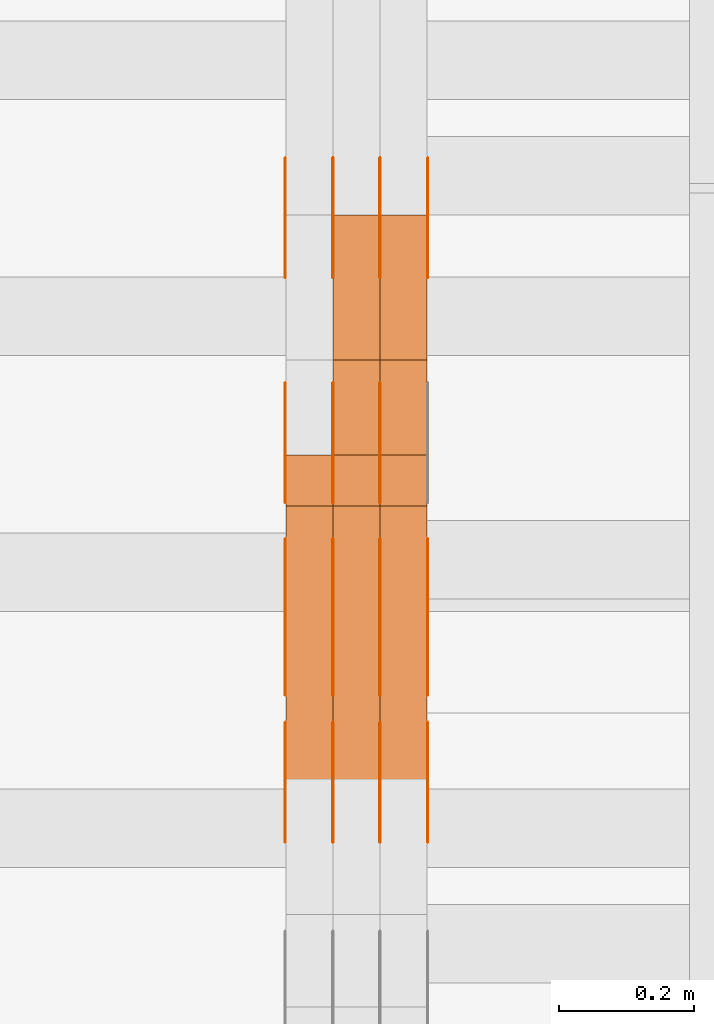
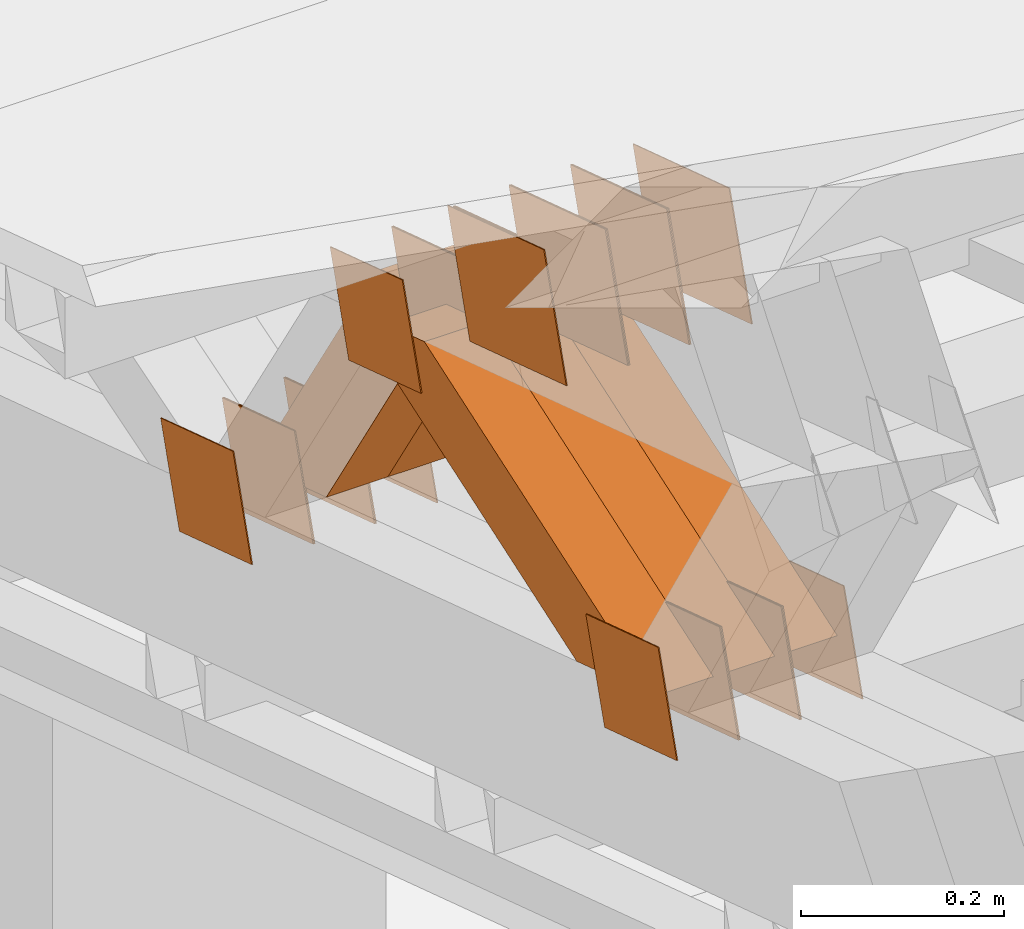
# One storey, part 171 of 385: 28 proxies.
"""IFC2X3 building model written with IfcOpenShell, lengths in millimetres."""

from ifc_helpers import new_model, entity, si_unit, converted_unit, derived_unit, direction, frame, origin, place, context, subcontext, project, spatial, polyline, outline, extrude, source, transform, mapped, material, type_object, type_shapes, element, save


model = new_model("IFC2X3")

# Units and contexts
model_context = context("Model", 3, precision=0.01, world=origin(), true_north=direction((6.12303176911189e-17, 1.0)))
body_context = subcontext(model_context, "Body", "Model", "MODEL_VIEW")
ifc_project = project(units=[si_unit("LENGTHUNIT", "METRE", prefix="MILLI"), si_unit("AREAUNIT", "SQUARE_METRE"), si_unit("VOLUMEUNIT", "CUBIC_METRE"), converted_unit("PLANEANGLEUNIT", "DEGREE", entity("IfcRatioMeasure", 0.0174532925199433), si_unit("PLANEANGLEUNIT", "RADIAN"), dimensions=[0, 0, 0, 0, 0, 0, 0]), si_unit("MASSUNIT", "GRAM", prefix="KILO"), derived_unit("MASSDENSITYUNIT", [(si_unit("MASSUNIT", "GRAM", prefix="KILO"), 1), (si_unit("LENGTHUNIT", "METRE"), -3)]), si_unit("TIMEUNIT", "SECOND"), si_unit("FREQUENCYUNIT", "HERTZ"), si_unit("THERMODYNAMICTEMPERATUREUNIT", "DEGREE_CELSIUS"), derived_unit("THERMALTRANSMITTANCEUNIT", [(si_unit("MASSUNIT", "GRAM", prefix="KILO"), 1), (si_unit("THERMODYNAMICTEMPERATUREUNIT", "KELVIN"), -1), (si_unit("TIMEUNIT", "SECOND"), -3)]), derived_unit("VOLUMETRICFLOWRATEUNIT", [(si_unit("LENGTHUNIT", "METRE"), 3), (si_unit("TIMEUNIT", "SECOND"), -1)]), si_unit("ELECTRICCURRENTUNIT", "AMPERE"), si_unit("ELECTRICVOLTAGEUNIT", "VOLT"), si_unit("POWERUNIT", "WATT"), si_unit("FORCEUNIT", "NEWTON", prefix="KILO"), si_unit("ILLUMINANCEUNIT", "LUX"), si_unit("LUMINOUSFLUXUNIT", "LUMEN"), si_unit("LUMINOUSINTENSITYUNIT", "CANDELA"), derived_unit("USERDEFINED", [(si_unit("MASSUNIT", "GRAM", prefix="KILO"), -1), (si_unit("LENGTHUNIT", "METRE"), -2), (si_unit("TIMEUNIT", "SECOND"), 3), (si_unit("LUMINOUSFLUXUNIT", "LUMEN"), 1)]), derived_unit("LINEARVELOCITYUNIT", [(si_unit("LENGTHUNIT", "METRE"), 1), (si_unit("TIMEUNIT", "SECOND"), -1)]), si_unit("PRESSUREUNIT", "PASCAL"), derived_unit("USERDEFINED", [(si_unit("LENGTHUNIT", "METRE"), -2), (si_unit("MASSUNIT", "GRAM", prefix="KILO"), 1), (si_unit("TIMEUNIT", "SECOND"), -2)])], contexts=[model_context])

# Site, building, storey
site_placement = place(None, origin())
site = spatial("IfcSite", under=ifc_project, at=site_placement, CompositionType="ELEMENT")
building_placement = place(site_placement, origin())
building = spatial("IfcBuilding", under=site, at=building_placement, CompositionType="ELEMENT")
storey_placement = place(building_placement, origin())
storey = spatial("IfcBuildingStorey", under=building, at=storey_placement, Name="Default", CompositionType="ELEMENT", Elevation=0.0)

# Proxies
ifc_material_1 = material(Name="IfcSurfaceStyle #40001")
building_element_proxy_type_1 = type_object("IfcBuildingElementProxyType", PredefinedType="NOTDEFINED", material=ifc_material_1)
shared_shape_1 = source(origin(), body_context, "Body", "SweptSolid", [
    extrude(outline(polyline([(-74.9998605591059, -59.9999264677526), (74.999875428623, -59.9999264677526), (74.9998605591068, 59.9999264677526), (-74.9998754286239, 59.9999264677526), (-74.9998605591059, -59.9999264677526)])), frame((75.0000889884782, 60.0000460315623, 0.0), z_axis=(0.0, 0.0, 1.0), x_axis=(-1.0, 0.0, 0.0)), (0.0, 0.0, 1.0), 1.3),
])
type_shapes(building_element_proxy_type_1, [shared_shape_1])
proxy_1_placement = place(building_placement, frame((315.0, 20621.9679769682, 2241.76551219004), z_axis=(-1.0, 0.0, 0.0), x_axis=(0.0, -0.951056516295154, 0.309016994374948)))
element("IfcBuildingElementProxy", 1, at=proxy_1_placement, inside=storey, type_object=building_element_proxy_type_1, material=ifc_material_1, context=body_context, shape_type="MappedRepresentation", body=[
    mapped(shared_shape_1, transform((0.0, 0.0, 0.0), scale=1.0)),
])
ifc_material_2 = material(Name="IfcSurfaceStyle #39944")
building_element_proxy_type_2 = type_object("IfcBuildingElementProxyType", PredefinedType="NOTDEFINED", material=ifc_material_2)
shared_shape_2 = source(origin(), body_context, "Body", "SweptSolid", [
    extrude(outline(polyline([(-74.9998605591059, -59.9999264677526), (74.999875428623, -59.9999264677526), (74.9998605591068, 59.9999264677526), (-74.9998754286239, 59.9999264677526), (-74.9998605591059, -59.9999264677526)])), frame((75.0000889884782, 60.0000460315623, 0.0), z_axis=(0.0, 0.0, 1.0), x_axis=(-1.0, 0.0, 0.0)), (0.0, 0.0, 1.0), 1.3),
])
type_shapes(building_element_proxy_type_2, [shared_shape_2])
proxy_2_placement = place(building_placement, frame((316.299999999986, 20621.9679769682, 2241.76551219004), z_axis=(-1.0, 0.0, 0.0), x_axis=(0.0, -0.951056516295154, 0.309016994374948)))
element("IfcBuildingElementProxy", 2, at=proxy_2_placement, inside=storey, type_object=building_element_proxy_type_2, material=ifc_material_2, context=body_context, shape_type="MappedRepresentation", body=[
    mapped(shared_shape_2, transform((0.0, 0.0, 0.0), scale=1.0)),
])
ifc_material_3 = material(Name="IfcSurfaceStyle #39887")
building_element_proxy_type_3 = type_object("IfcBuildingElementProxyType", PredefinedType="NOTDEFINED", material=ifc_material_3)
shared_shape_3 = source(origin(), body_context, "Body", "SweptSolid", [
    extrude(outline(polyline([(-74.9998605591059, -59.9999264677526), (74.999875428623, -59.9999264677526), (74.9998605591068, 59.9999264677526), (-74.9998754286239, 59.9999264677526), (-74.9998605591059, -59.9999264677526)])), frame((75.0000889884782, 60.0000460315623, 0.0), z_axis=(0.0, 0.0, 1.0), x_axis=(-1.0, 0.0, 0.0)), (0.0, 0.0, 1.0), 1.29999999999999),
])
type_shapes(building_element_proxy_type_3, [shared_shape_3])
proxy_3_placement = place(building_placement, frame((245.0, 20621.9679769682, 2241.76551219004), z_axis=(-1.0, 0.0, 0.0), x_axis=(0.0, -0.951056516295154, 0.309016994374948)))
element("IfcBuildingElementProxy", 3, at=proxy_3_placement, inside=storey, type_object=building_element_proxy_type_3, material=ifc_material_3, context=body_context, shape_type="MappedRepresentation", body=[
    mapped(shared_shape_3, transform((0.0, 0.0, 0.0), scale=1.0)),
])
ifc_material_4 = material(Name="IfcSurfaceStyle #39830")
building_element_proxy_type_4 = type_object("IfcBuildingElementProxyType", PredefinedType="NOTDEFINED", material=ifc_material_4)
shared_shape_4 = source(origin(), body_context, "Body", "SweptSolid", [
    extrude(outline(polyline([(-74.9998605591059, -59.9999264677526), (74.999875428623, -59.9999264677526), (74.9998605591068, 59.9999264677526), (-74.9998754286239, 59.9999264677526), (-74.9998605591059, -59.9999264677526)])), frame((75.0000889884782, 60.0000460315623, 0.0), z_axis=(0.0, 0.0, 1.0), x_axis=(-1.0, 0.0, 0.0)), (0.0, 0.0, 1.0), 1.29999999999999),
])
type_shapes(building_element_proxy_type_4, [shared_shape_4])
proxy_4_placement = place(building_placement, frame((246.299999999986, 20621.9679769682, 2241.76551219004), z_axis=(-1.0, 0.0, 0.0), x_axis=(0.0, -0.951056516295154, 0.309016994374948)))
element("IfcBuildingElementProxy", 4, at=proxy_4_placement, inside=storey, type_object=building_element_proxy_type_4, material=ifc_material_4, context=body_context, shape_type="MappedRepresentation", body=[
    mapped(shared_shape_4, transform((0.0, 0.0, 0.0), scale=1.0)),
])
ifc_material_5 = material(Name="IfcSurfaceStyle #39773")
building_element_proxy_type_5 = type_object("IfcBuildingElementProxyType", PredefinedType="NOTDEFINED", material=ifc_material_5)
shared_shape_5 = source(origin(), body_context, "Body", "SweptSolid", [
    extrude(outline(polyline([(-74.9998605591059, -59.9999264677526), (74.999875428623, -59.9999264677526), (74.9998605591068, 59.9999264677526), (-74.9998754286239, 59.9999264677526), (-74.9998605591059, -59.9999264677526)])), frame((75.0000889884782, 60.0000460315623, 0.0), z_axis=(0.0, 0.0, 1.0), x_axis=(-1.0, 0.0, 0.0)), (0.0, 0.0, 1.0), 1.29999999999999),
])
type_shapes(building_element_proxy_type_5, [shared_shape_5])
proxy_5_placement = place(building_placement, frame((175.0, 20621.9679769682, 2241.76551219004), z_axis=(-1.0, 0.0, 0.0), x_axis=(0.0, -0.951056516295154, 0.309016994374948)))
element("IfcBuildingElementProxy", 5, at=proxy_5_placement, inside=storey, type_object=building_element_proxy_type_5, material=ifc_material_5, context=body_context, shape_type="MappedRepresentation", body=[
    mapped(shared_shape_5, transform((0.0, 0.0, 0.0), scale=1.0)),
])
ifc_material_6 = material(Name="IfcSurfaceStyle #38348")
building_element_proxy_type_6 = type_object("IfcBuildingElementProxyType", PredefinedType="NOTDEFINED", material=ifc_material_6)
shared_shape_6 = source(origin(), body_context, "Body", "SweptSolid", [
    extrude(outline(polyline([(-100.000260677523, -72.0000050220369), (100.000341220114, -72.0000050220369), (99.9997962944585, 72.0000050220369), (-99.9998768370492, 72.0000050220369), (-100.000260677523, -72.0000050220369)])), frame((100.000341220114, 72.0001826453454, 0.0), z_axis=(0.0, 0.0, 1.0), x_axis=(-1.0, 0.0, 0.0)), (0.0, 0.0, 1.0), 1.3),
])
type_shapes(building_element_proxy_type_6, [shared_shape_6])
proxy_6_placement = place(building_placement, frame((386.299999999986, 20382.8706354426, 2409.35285895246), z_axis=(-1.0, 0.0, 0.0), x_axis=(0.0, -0.951056516295154, 0.309016994374948)))
element("IfcBuildingElementProxy", 6, at=proxy_6_placement, inside=storey, type_object=building_element_proxy_type_6, material=ifc_material_6, context=body_context, shape_type="MappedRepresentation", body=[
    mapped(shared_shape_6, transform((0.0, 0.0, 0.0), scale=1.0)),
])
ifc_material_7 = material(Name="IfcSurfaceStyle #38291")
building_element_proxy_type_7 = type_object("IfcBuildingElementProxyType", PredefinedType="NOTDEFINED", material=ifc_material_7)
shared_shape_7 = source(origin(), body_context, "Body", "SweptSolid", [
    extrude(outline(polyline([(-100.000260677523, -72.0000050220369), (100.000341220114, -72.0000050220369), (99.9997962944585, 72.0000050220369), (-99.9998768370492, 72.0000050220369), (-100.000260677523, -72.0000050220369)])), frame((100.000341220114, 72.0001826453454, 0.0), z_axis=(0.0, 0.0, 1.0), x_axis=(-1.0, 0.0, 0.0)), (0.0, 0.0, 1.0), 1.3),
])
type_shapes(building_element_proxy_type_7, [shared_shape_7])
proxy_7_placement = place(building_placement, frame((315.0, 20382.8706354426, 2409.35285895246), z_axis=(-1.0, 0.0, 0.0), x_axis=(0.0, -0.951056516295154, 0.309016994374948)))
element("IfcBuildingElementProxy", 7, at=proxy_7_placement, inside=storey, type_object=building_element_proxy_type_7, material=ifc_material_7, context=body_context, shape_type="MappedRepresentation", body=[
    mapped(shared_shape_7, transform((0.0, 0.0, 0.0), scale=1.0)),
])
ifc_material_8 = material(Name="IfcSurfaceStyle #38234")
building_element_proxy_type_8 = type_object("IfcBuildingElementProxyType", PredefinedType="NOTDEFINED", material=ifc_material_8)
shared_shape_8 = source(origin(), body_context, "Body", "SweptSolid", [
    extrude(outline(polyline([(-100.000260677523, -72.0000050220369), (100.000341220114, -72.0000050220369), (99.9997962944585, 72.0000050220369), (-99.9998768370492, 72.0000050220369), (-100.000260677523, -72.0000050220369)])), frame((100.000341220114, 72.0001826453454, 0.0), z_axis=(0.0, 0.0, 1.0), x_axis=(-1.0, 0.0, 0.0)), (0.0, 0.0, 1.0), 1.3),
])
type_shapes(building_element_proxy_type_8, [shared_shape_8])
proxy_8_placement = place(building_placement, frame((316.299999999986, 20382.8706354426, 2409.35285895246), z_axis=(-1.0, 0.0, 0.0), x_axis=(0.0, -0.951056516295154, 0.309016994374948)))
element("IfcBuildingElementProxy", 8, at=proxy_8_placement, inside=storey, type_object=building_element_proxy_type_8, material=ifc_material_8, context=body_context, shape_type="MappedRepresentation", body=[
    mapped(shared_shape_8, transform((0.0, 0.0, 0.0), scale=1.0)),
])
ifc_material_9 = material(Name="IfcSurfaceStyle #38177")
building_element_proxy_type_9 = type_object("IfcBuildingElementProxyType", PredefinedType="NOTDEFINED", material=ifc_material_9)
shared_shape_9 = source(origin(), body_context, "Body", "SweptSolid", [
    extrude(outline(polyline([(-100.000260677523, -72.0000050220369), (100.000341220114, -72.0000050220369), (99.9997962944585, 72.0000050220369), (-99.9998768370492, 72.0000050220369), (-100.000260677523, -72.0000050220369)])), frame((100.000341220114, 72.0001826453454, 0.0), z_axis=(0.0, 0.0, 1.0), x_axis=(-1.0, 0.0, 0.0)), (0.0, 0.0, 1.0), 1.29999999999998),
])
type_shapes(building_element_proxy_type_9, [shared_shape_9])
proxy_9_placement = place(building_placement, frame((245.0, 20382.8706354426, 2409.35285895246), z_axis=(-1.0, 0.0, 0.0), x_axis=(0.0, -0.951056516295154, 0.309016994374948)))
element("IfcBuildingElementProxy", 9, at=proxy_9_placement, inside=storey, type_object=building_element_proxy_type_9, material=ifc_material_9, context=body_context, shape_type="MappedRepresentation", body=[
    mapped(shared_shape_9, transform((0.0, 0.0, 0.0), scale=1.0)),
])
ifc_material_10 = material(Name="IfcSurfaceStyle #38120")
building_element_proxy_type_10 = type_object("IfcBuildingElementProxyType", PredefinedType="NOTDEFINED", material=ifc_material_10)
shared_shape_10 = source(origin(), body_context, "Body", "SweptSolid", [
    extrude(outline(polyline([(-100.000260677523, -72.0000050220369), (100.000341220114, -72.0000050220369), (99.9997962944585, 72.0000050220369), (-99.9998768370492, 72.0000050220369), (-100.000260677523, -72.0000050220369)])), frame((100.000341220114, 72.0001826453454, 0.0), z_axis=(0.0, 0.0, 1.0), x_axis=(-1.0, 0.0, 0.0)), (0.0, 0.0, 1.0), 1.29999999999998),
])
type_shapes(building_element_proxy_type_10, [shared_shape_10])
proxy_10_placement = place(building_placement, frame((246.299999999986, 20382.8706354426, 2409.35285895246), z_axis=(-1.0, 0.0, 0.0), x_axis=(0.0, -0.951056516295154, 0.309016994374948)))
element("IfcBuildingElementProxy", 10, at=proxy_10_placement, inside=storey, type_object=building_element_proxy_type_10, material=ifc_material_10, context=body_context, shape_type="MappedRepresentation", body=[
    mapped(shared_shape_10, transform((0.0, 0.0, 0.0), scale=1.0)),
])
ifc_material_11 = material(Name="IfcSurfaceStyle #38063")
building_element_proxy_type_11 = type_object("IfcBuildingElementProxyType", PredefinedType="NOTDEFINED", material=ifc_material_11)
shared_shape_11 = source(origin(), body_context, "Body", "SweptSolid", [
    extrude(outline(polyline([(-100.000260677523, -72.0000050220369), (100.000341220114, -72.0000050220369), (99.9997962944585, 72.0000050220369), (-99.9998768370492, 72.0000050220369), (-100.000260677523, -72.0000050220369)])), frame((100.000341220114, 72.0001826453454, 0.0), z_axis=(0.0, 0.0, 1.0), x_axis=(-1.0, 0.0, 0.0)), (0.0, 0.0, 1.0), 1.29999999999999),
])
type_shapes(building_element_proxy_type_11, [shared_shape_11])
proxy_11_placement = place(building_placement, frame((175.0, 20382.8706354426, 2409.35285895246), z_axis=(-1.0, 0.0, 0.0), x_axis=(0.0, -0.951056516295154, 0.309016994374948)))
element("IfcBuildingElementProxy", 11, at=proxy_11_placement, inside=storey, type_object=building_element_proxy_type_11, material=ifc_material_11, context=body_context, shape_type="MappedRepresentation", body=[
    mapped(shared_shape_11, transform((0.0, 0.0, 0.0), scale=1.0)),
])
ifc_material_12 = material(Name="IfcSurfaceStyle #31850")
building_element_proxy_type_12 = type_object("IfcBuildingElementProxyType", PredefinedType="NOTDEFINED", material=ifc_material_12)
shared_shape_12 = source(origin(), body_context, "Body", "SweptSolid", [
    extrude(outline(polyline([(-74.9998605591118, -59.9999264677598), (74.9998754286171, -59.9999264677598), (74.9998605591136, 59.9999264677598), (-74.9998754286189, 59.9999264677598), (-74.9998605591118, -59.9999264677598)])), frame((75.0000347664736, 60.0000016373434, 0.0), z_axis=(0.0, 0.0, 1.0), x_axis=(-1.0, 0.0, 0.0)), (0.0, 0.0, 1.0), 1.3),
])
type_shapes(building_element_proxy_type_12, [shared_shape_12])
proxy_12_placement = place(building_placement, frame((386.299999999986, 20117.0890328685, 2105.40814929196), z_axis=(-1.0, 0.0, 0.0), x_axis=(0.0, -0.951056516295124, 0.309016994375039)))
element("IfcBuildingElementProxy", 12, at=proxy_12_placement, inside=storey, type_object=building_element_proxy_type_12, material=ifc_material_12, context=body_context, shape_type="MappedRepresentation", body=[
    mapped(shared_shape_12, transform((0.0, 0.0, 0.0), scale=1.0)),
])
ifc_material_13 = material(Name="IfcSurfaceStyle #31793")
building_element_proxy_type_13 = type_object("IfcBuildingElementProxyType", PredefinedType="NOTDEFINED", material=ifc_material_13)
shared_shape_13 = source(origin(), body_context, "Body", "SweptSolid", [
    extrude(outline(polyline([(-74.9998605591118, -59.9999264677598), (74.9998754286171, -59.9999264677598), (74.9998605591136, 59.9999264677598), (-74.9998754286189, 59.9999264677598), (-74.9998605591118, -59.9999264677598)])), frame((75.0000347664736, 60.0000016373434, 0.0), z_axis=(0.0, 0.0, 1.0), x_axis=(-1.0, 0.0, 0.0)), (0.0, 0.0, 1.0), 1.3),
])
type_shapes(building_element_proxy_type_13, [shared_shape_13])
proxy_13_placement = place(building_placement, frame((315.0, 20117.0890328685, 2105.40814929196), z_axis=(-1.0, 0.0, 0.0), x_axis=(0.0, -0.951056516295124, 0.309016994375039)))
element("IfcBuildingElementProxy", 13, at=proxy_13_placement, inside=storey, type_object=building_element_proxy_type_13, material=ifc_material_13, context=body_context, shape_type="MappedRepresentation", body=[
    mapped(shared_shape_13, transform((0.0, 0.0, 0.0), scale=1.0)),
])
ifc_material_14 = material(Name="IfcSurfaceStyle #31736")
building_element_proxy_type_14 = type_object("IfcBuildingElementProxyType", PredefinedType="NOTDEFINED", material=ifc_material_14)
shared_shape_14 = source(origin(), body_context, "Body", "SweptSolid", [
    extrude(outline(polyline([(-74.9998605591118, -59.9999264677598), (74.9998754286171, -59.9999264677598), (74.9998605591136, 59.9999264677598), (-74.9998754286189, 59.9999264677598), (-74.9998605591118, -59.9999264677598)])), frame((75.0000347664736, 60.0000016373434, 0.0), z_axis=(0.0, 0.0, 1.0), x_axis=(-1.0, 0.0, 0.0)), (0.0, 0.0, 1.0), 1.3),
])
type_shapes(building_element_proxy_type_14, [shared_shape_14])
proxy_14_placement = place(building_placement, frame((316.299999999986, 20117.0890328685, 2105.40814929196), z_axis=(-1.0, 0.0, 0.0), x_axis=(0.0, -0.951056516295124, 0.309016994375039)))
element("IfcBuildingElementProxy", 14, at=proxy_14_placement, inside=storey, type_object=building_element_proxy_type_14, material=ifc_material_14, context=body_context, shape_type="MappedRepresentation", body=[
    mapped(shared_shape_14, transform((0.0, 0.0, 0.0), scale=1.0)),
])
ifc_material_15 = material(Name="IfcSurfaceStyle #31679")
building_element_proxy_type_15 = type_object("IfcBuildingElementProxyType", PredefinedType="NOTDEFINED", material=ifc_material_15)
shared_shape_15 = source(origin(), body_context, "Body", "SweptSolid", [
    extrude(outline(polyline([(-74.9998605591118, -59.9999264677598), (74.9998754286171, -59.9999264677598), (74.9998605591136, 59.9999264677598), (-74.9998754286189, 59.9999264677598), (-74.9998605591118, -59.9999264677598)])), frame((75.0000347664736, 60.0000016373434, 0.0), z_axis=(0.0, 0.0, 1.0), x_axis=(-1.0, 0.0, 0.0)), (0.0, 0.0, 1.0), 1.29999999999999),
])
type_shapes(building_element_proxy_type_15, [shared_shape_15])
proxy_15_placement = place(building_placement, frame((245.0, 20117.0890328685, 2105.40814929196), z_axis=(-1.0, 0.0, 0.0), x_axis=(0.0, -0.951056516295124, 0.309016994375039)))
element("IfcBuildingElementProxy", 15, at=proxy_15_placement, inside=storey, type_object=building_element_proxy_type_15, material=ifc_material_15, context=body_context, shape_type="MappedRepresentation", body=[
    mapped(shared_shape_15, transform((0.0, 0.0, 0.0), scale=1.0)),
])
ifc_material_16 = material(Name="IfcSurfaceStyle #31622")
building_element_proxy_type_16 = type_object("IfcBuildingElementProxyType", PredefinedType="NOTDEFINED", material=ifc_material_16)
shared_shape_16 = source(origin(), body_context, "Body", "SweptSolid", [
    extrude(outline(polyline([(-74.9998605591118, -59.9999264677598), (74.9998754286171, -59.9999264677598), (74.9998605591136, 59.9999264677598), (-74.9998754286189, 59.9999264677598), (-74.9998605591118, -59.9999264677598)])), frame((75.0000347664736, 60.0000016373434, 0.0), z_axis=(0.0, 0.0, 1.0), x_axis=(-1.0, 0.0, 0.0)), (0.0, 0.0, 1.0), 1.29999999999999),
])
type_shapes(building_element_proxy_type_16, [shared_shape_16])
proxy_16_placement = place(building_placement, frame((246.299999999986, 20117.0890328685, 2105.40814929196), z_axis=(-1.0, 0.0, 0.0), x_axis=(0.0, -0.951056516295124, 0.309016994375039)))
element("IfcBuildingElementProxy", 16, at=proxy_16_placement, inside=storey, type_object=building_element_proxy_type_16, material=ifc_material_16, context=body_context, shape_type="MappedRepresentation", body=[
    mapped(shared_shape_16, transform((0.0, 0.0, 0.0), scale=1.0)),
])
ifc_material_17 = material(Name="IfcSurfaceStyle #31565")
building_element_proxy_type_17 = type_object("IfcBuildingElementProxyType", PredefinedType="NOTDEFINED", material=ifc_material_17)
shared_shape_17 = source(origin(), body_context, "Body", "SweptSolid", [
    extrude(outline(polyline([(-74.9998605591118, -59.9999264677598), (74.9998754286171, -59.9999264677598), (74.9998605591136, 59.9999264677598), (-74.9998754286189, 59.9999264677598), (-74.9998605591118, -59.9999264677598)])), frame((75.0000347664736, 60.0000016373434, 0.0), z_axis=(0.0, 0.0, 1.0), x_axis=(-1.0, 0.0, 0.0)), (0.0, 0.0, 1.0), 1.29999999999999),
])
type_shapes(building_element_proxy_type_17, [shared_shape_17])
proxy_17_placement = place(building_placement, frame((175.0, 20117.0890328685, 2105.40814929196), z_axis=(-1.0, 0.0, 0.0), x_axis=(0.0, -0.951056516295124, 0.309016994375039)))
element("IfcBuildingElementProxy", 17, at=proxy_17_placement, inside=storey, type_object=building_element_proxy_type_17, material=ifc_material_17, context=body_context, shape_type="MappedRepresentation", body=[
    mapped(shared_shape_17, transform((0.0, 0.0, 0.0), scale=1.0)),
])
ifc_material_18 = material(Name="IfcSurfaceStyle #31508")
building_element_proxy_type_18 = type_object("IfcBuildingElementProxyType", PredefinedType="NOTDEFINED", material=ifc_material_18)
shared_shape_18 = source(origin(), body_context, "Body", "SweptSolid", [
    extrude(outline(polyline([(-74.9998794200132, -59.999984515643), (74.9998565677174, -59.999984515643), (74.9998794200123, 59.999984515643), (-74.9998565677165, 59.999984515643), (-74.9998794200132, -59.999984515643)])), frame((75.0002235343086, 60.0000596852268, 0.0), z_axis=(0.0, 0.0, 1.0), x_axis=(-1.0, 0.0, 0.0)), (0.0, 0.0, 1.0), 1.3),
])
type_shapes(building_element_proxy_type_18, [shared_shape_18])
proxy_18_placement = place(building_placement, frame((386.299999999986, 20956.2317725846, 1832.75404405346), z_axis=(-1.0, 0.0, 0.0), x_axis=(0.0, -0.951056516295124, 0.309016994375039)))
element("IfcBuildingElementProxy", 18, at=proxy_18_placement, inside=storey, type_object=building_element_proxy_type_18, material=ifc_material_18, context=body_context, shape_type="MappedRepresentation", body=[
    mapped(shared_shape_18, transform((0.0, 0.0, 0.0), scale=1.0)),
])
ifc_material_19 = material(Name="IfcSurfaceStyle #31451")
building_element_proxy_type_19 = type_object("IfcBuildingElementProxyType", PredefinedType="NOTDEFINED", material=ifc_material_19)
shared_shape_19 = source(origin(), body_context, "Body", "SweptSolid", [
    extrude(outline(polyline([(-74.9998794200132, -59.999984515643), (74.9998565677174, -59.999984515643), (74.9998794200123, 59.999984515643), (-74.9998565677165, 59.999984515643), (-74.9998794200132, -59.999984515643)])), frame((75.0002235343086, 60.0000596852268, 0.0), z_axis=(0.0, 0.0, 1.0), x_axis=(-1.0, 0.0, 0.0)), (0.0, 0.0, 1.0), 1.3),
])
type_shapes(building_element_proxy_type_19, [shared_shape_19])
proxy_19_placement = place(building_placement, frame((315.0, 20956.2317725846, 1832.75404405346), z_axis=(-1.0, 0.0, 0.0), x_axis=(0.0, -0.951056516295124, 0.309016994375039)))
element("IfcBuildingElementProxy", 19, at=proxy_19_placement, inside=storey, type_object=building_element_proxy_type_19, material=ifc_material_19, context=body_context, shape_type="MappedRepresentation", body=[
    mapped(shared_shape_19, transform((0.0, 0.0, 0.0), scale=1.0)),
])
ifc_material_20 = material(Name="IfcSurfaceStyle #31394")
building_element_proxy_type_20 = type_object("IfcBuildingElementProxyType", PredefinedType="NOTDEFINED", material=ifc_material_20)
shared_shape_20 = source(origin(), body_context, "Body", "SweptSolid", [
    extrude(outline(polyline([(-74.9998794200132, -59.999984515643), (74.9998565677174, -59.999984515643), (74.9998794200123, 59.999984515643), (-74.9998565677165, 59.999984515643), (-74.9998794200132, -59.999984515643)])), frame((75.0002235343086, 60.0000596852268, 0.0), z_axis=(0.0, 0.0, 1.0), x_axis=(-1.0, 0.0, 0.0)), (0.0, 0.0, 1.0), 1.3),
])
type_shapes(building_element_proxy_type_20, [shared_shape_20])
proxy_20_placement = place(building_placement, frame((316.299999999986, 20956.2317725846, 1832.75404405346), z_axis=(-1.0, 0.0, 0.0), x_axis=(0.0, -0.951056516295124, 0.309016994375039)))
element("IfcBuildingElementProxy", 20, at=proxy_20_placement, inside=storey, type_object=building_element_proxy_type_20, material=ifc_material_20, context=body_context, shape_type="MappedRepresentation", body=[
    mapped(shared_shape_20, transform((0.0, 0.0, 0.0), scale=1.0)),
])
ifc_material_21 = material(Name="IfcSurfaceStyle #31337")
building_element_proxy_type_21 = type_object("IfcBuildingElementProxyType", PredefinedType="NOTDEFINED", material=ifc_material_21)
shared_shape_21 = source(origin(), body_context, "Body", "SweptSolid", [
    extrude(outline(polyline([(-74.9998794200132, -59.999984515643), (74.9998565677174, -59.999984515643), (74.9998794200123, 59.999984515643), (-74.9998565677165, 59.999984515643), (-74.9998794200132, -59.999984515643)])), frame((75.0002235343086, 60.0000596852268, 0.0), z_axis=(0.0, 0.0, 1.0), x_axis=(-1.0, 0.0, 0.0)), (0.0, 0.0, 1.0), 1.29999999999999),
])
type_shapes(building_element_proxy_type_21, [shared_shape_21])
proxy_21_placement = place(building_placement, frame((245.0, 20956.2317725846, 1832.75404405346), z_axis=(-1.0, 0.0, 0.0), x_axis=(0.0, -0.951056516295124, 0.309016994375039)))
element("IfcBuildingElementProxy", 21, at=proxy_21_placement, inside=storey, type_object=building_element_proxy_type_21, material=ifc_material_21, context=body_context, shape_type="MappedRepresentation", body=[
    mapped(shared_shape_21, transform((0.0, 0.0, 0.0), scale=1.0)),
])
ifc_material_22 = material(Name="IfcSurfaceStyle #31280")
building_element_proxy_type_22 = type_object("IfcBuildingElementProxyType", PredefinedType="NOTDEFINED", material=ifc_material_22)
shared_shape_22 = source(origin(), body_context, "Body", "SweptSolid", [
    extrude(outline(polyline([(-74.9998794200132, -59.999984515643), (74.9998565677174, -59.999984515643), (74.9998794200123, 59.999984515643), (-74.9998565677165, 59.999984515643), (-74.9998794200132, -59.999984515643)])), frame((75.0002235343086, 60.0000596852268, 0.0), z_axis=(0.0, 0.0, 1.0), x_axis=(-1.0, 0.0, 0.0)), (0.0, 0.0, 1.0), 1.29999999999999),
])
type_shapes(building_element_proxy_type_22, [shared_shape_22])
proxy_22_placement = place(building_placement, frame((246.299999999986, 20956.2317725846, 1832.75404405346), z_axis=(-1.0, 0.0, 0.0), x_axis=(0.0, -0.951056516295124, 0.309016994375039)))
element("IfcBuildingElementProxy", 22, at=proxy_22_placement, inside=storey, type_object=building_element_proxy_type_22, material=ifc_material_22, context=body_context, shape_type="MappedRepresentation", body=[
    mapped(shared_shape_22, transform((0.0, 0.0, 0.0), scale=1.0)),
])
ifc_material_23 = material(Name="IfcSurfaceStyle #31223")
building_element_proxy_type_23 = type_object("IfcBuildingElementProxyType", PredefinedType="NOTDEFINED", material=ifc_material_23)
shared_shape_23 = source(origin(), body_context, "Body", "SweptSolid", [
    extrude(outline(polyline([(-74.9998794200132, -59.999984515643), (74.9998565677174, -59.999984515643), (74.9998794200123, 59.999984515643), (-74.9998565677165, 59.999984515643), (-74.9998794200132, -59.999984515643)])), frame((75.0002235343086, 60.0000596852268, 0.0), z_axis=(0.0, 0.0, 1.0), x_axis=(-1.0, 0.0, 0.0)), (0.0, 0.0, 1.0), 1.29999999999999),
])
type_shapes(building_element_proxy_type_23, [shared_shape_23])
proxy_23_placement = place(building_placement, frame((175.0, 20956.2317725846, 1832.75404405346), z_axis=(-1.0, 0.0, 0.0), x_axis=(0.0, -0.951056516295124, 0.309016994375039)))
element("IfcBuildingElementProxy", 23, at=proxy_23_placement, inside=storey, type_object=building_element_proxy_type_23, material=ifc_material_23, context=body_context, shape_type="MappedRepresentation", body=[
    mapped(shared_shape_23, transform((0.0, 0.0, 0.0), scale=1.0)),
])
ifc_material_24 = material(Name="IfcSurfaceStyle #14246")
building_element_proxy_type_24 = type_object("IfcBuildingElementProxyType", Name="T1-W26 14244", PredefinedType="NOTDEFINED", material=ifc_material_24)
shared_shape_24 = source(origin(), body_context, "Body", "SweptSolid", [
    extrude(outline(polyline([(-339.390941716546, -47.5001331548025), (137.738864791781, -47.5001331548025), (201.272298560955, 6.02772073885038e-05), (212.703852542003, 47.5001030161988), (-212.324074178193, 47.5001030161988), (-339.390941716546, -47.5001331548025)])), frame((212.703852542003, 47.5001030161988, 0.0), z_axis=(0.0, 0.0, 1.0), x_axis=(-1.0, 0.0, 0.0)), (0.0, 0.0, 1.0), 70.0),
])
type_shapes(building_element_proxy_type_24, [shared_shape_24])
proxy_24_placement = place(building_placement, frame((385.0, 20576.541015625, 2286.80981445313), z_axis=(-1.0, 0.0, 0.0), x_axis=(0.0, -0.946743816465327, -0.321987804093053)))
element("IfcBuildingElementProxy", 24, at=proxy_24_placement, inside=storey, type_object=building_element_proxy_type_24, material=ifc_material_24, Name="T1-W26", context=body_context, shape_type="MappedRepresentation", body=[
    mapped(shared_shape_24, transform((0.0, 0.0, 0.0), scale=1.0)),
])
ifc_material_25 = material(Name="IfcSurfaceStyle #14180")
building_element_proxy_type_25 = type_object("IfcBuildingElementProxyType", Name="T1-W26 14178", PredefinedType="NOTDEFINED", material=ifc_material_25)
shared_shape_25 = source(origin(), body_context, "Body", "SweptSolid", [
    extrude(outline(polyline([(-339.390941716546, -47.5001331548025), (137.738864791781, -47.5001331548025), (201.272298560955, 6.02772073885038e-05), (212.703852542003, 47.5001030161988), (-212.324074178193, 47.5001030161988), (-339.390941716546, -47.5001331548025)])), frame((212.703852542003, 47.5001030161988, 0.0), z_axis=(0.0, 0.0, 1.0), x_axis=(-1.0, 0.0, 0.0)), (0.0, 0.0, 1.0), 70.0),
])
type_shapes(building_element_proxy_type_25, [shared_shape_25])
proxy_25_placement = place(building_placement, frame((315.0, 20576.541015625, 2286.80981445313), z_axis=(-1.0, 0.0, 0.0), x_axis=(0.0, -0.946743816465327, -0.321987804093053)))
element("IfcBuildingElementProxy", 25, at=proxy_25_placement, inside=storey, type_object=building_element_proxy_type_25, material=ifc_material_25, Name="T1-W26", context=body_context, shape_type="MappedRepresentation", body=[
    mapped(shared_shape_25, transform((0.0, 0.0, 0.0), scale=1.0)),
])
ifc_material_26 = material(Name="IfcSurfaceStyle #14114")
building_element_proxy_type_26 = type_object("IfcBuildingElementProxyType", Name="T1-W26 14112", PredefinedType="NOTDEFINED", material=ifc_material_26)
shared_shape_26 = source(origin(), body_context, "Body", "SweptSolid", [
    extrude(outline(polyline([(-339.390941716546, -47.5001331548025), (137.738864791781, -47.5001331548025), (201.272298560955, 6.02772073885038e-05), (212.703852542003, 47.5001030161988), (-212.324074178193, 47.5001030161988), (-339.390941716546, -47.5001331548025)])), frame((212.703852542003, 47.5001030161988, 0.0), z_axis=(0.0, 0.0, 1.0), x_axis=(-1.0, 0.0, 0.0)), (0.0, 0.0, 1.0), 70.0),
])
type_shapes(building_element_proxy_type_26, [shared_shape_26])
proxy_26_placement = place(building_placement, frame((245.0, 20576.541015625, 2286.80981445313), z_axis=(-1.0, 0.0, 0.0), x_axis=(0.0, -0.946743816465327, -0.321987804093053)))
element("IfcBuildingElementProxy", 26, at=proxy_26_placement, inside=storey, type_object=building_element_proxy_type_26, material=ifc_material_26, Name="T1-W26", context=body_context, shape_type="MappedRepresentation", body=[
    mapped(shared_shape_26, transform((0.0, 0.0, 0.0), scale=1.0)),
])
ifc_material_27 = material(Name="IfcSurfaceStyle #13850")
building_element_proxy_type_27 = type_object("IfcBuildingElementProxyType", Name="T1-W29 13848", PredefinedType="NOTDEFINED", material=ifc_material_27)
shared_shape_27 = source(origin(), body_context, "Body", "SweptSolid", [
    extrude(outline(polyline([(-202.325994317059, -47.5000867467013), (200.714255560873, -47.5000867467013), (187.834128885383, 0.000593513395139059), (130.590899902046, 47.4997899900038), (-316.813290031243, 47.4997899900038), (-202.325994317059, -47.5000867467013)])), frame((200.714255560873, 47.5001935424745, 0.0), z_axis=(0.0, 0.0, 1.0), x_axis=(-1.0, 0.0, 0.0)), (0.0, 0.0, 1.0), 70.0),
])
type_shapes(building_element_proxy_type_27, [shared_shape_27])
proxy_27_placement = place(building_placement, frame((385.0, 20827.0771193222, 1890.72342063252), z_axis=(-1.0, 0.0, 0.0), x_axis=(0.0, -0.534567451138397, 0.845125813227473)))
element("IfcBuildingElementProxy", 27, at=proxy_27_placement, inside=storey, type_object=building_element_proxy_type_27, material=ifc_material_27, Name="T1-W29", context=body_context, shape_type="MappedRepresentation", body=[
    mapped(shared_shape_27, transform((0.0, 0.0, 0.0), scale=1.0)),
])
ifc_material_28 = material(Name="IfcSurfaceStyle #13784")
building_element_proxy_type_28 = type_object("IfcBuildingElementProxyType", Name="T1-W29 13782", PredefinedType="NOTDEFINED", material=ifc_material_28)
shared_shape_28 = source(origin(), body_context, "Body", "SweptSolid", [
    extrude(outline(polyline([(-202.325994317059, -47.5000867467013), (200.714255560873, -47.5000867467013), (187.834128885383, 0.000593513395139059), (130.590899902046, 47.4997899900038), (-316.813290031243, 47.4997899900038), (-202.325994317059, -47.5000867467013)])), frame((200.714255560873, 47.5001935424745, 0.0), z_axis=(0.0, 0.0, 1.0), x_axis=(-1.0, 0.0, 0.0)), (0.0, 0.0, 1.0), 70.0),
])
type_shapes(building_element_proxy_type_28, [shared_shape_28])
proxy_28_placement = place(building_placement, frame((315.0, 20827.0771193222, 1890.72342063252), z_axis=(-1.0, 0.0, 0.0), x_axis=(0.0, -0.534567451138397, 0.845125813227473)))
element("IfcBuildingElementProxy", 28, at=proxy_28_placement, inside=storey, type_object=building_element_proxy_type_28, material=ifc_material_28, Name="T1-W29", context=body_context, shape_type="MappedRepresentation", body=[
    mapped(shared_shape_28, transform((0.0, 0.0, 0.0), scale=1.0)),
])

save(model, "model.ifc")
